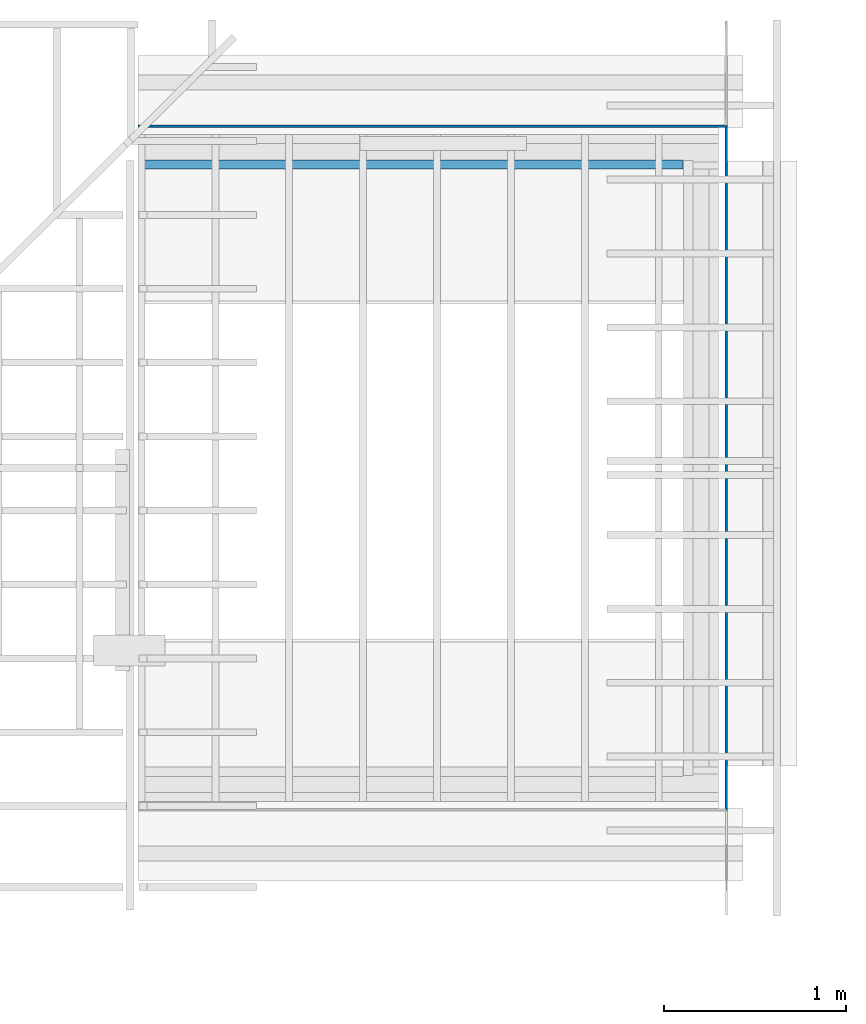
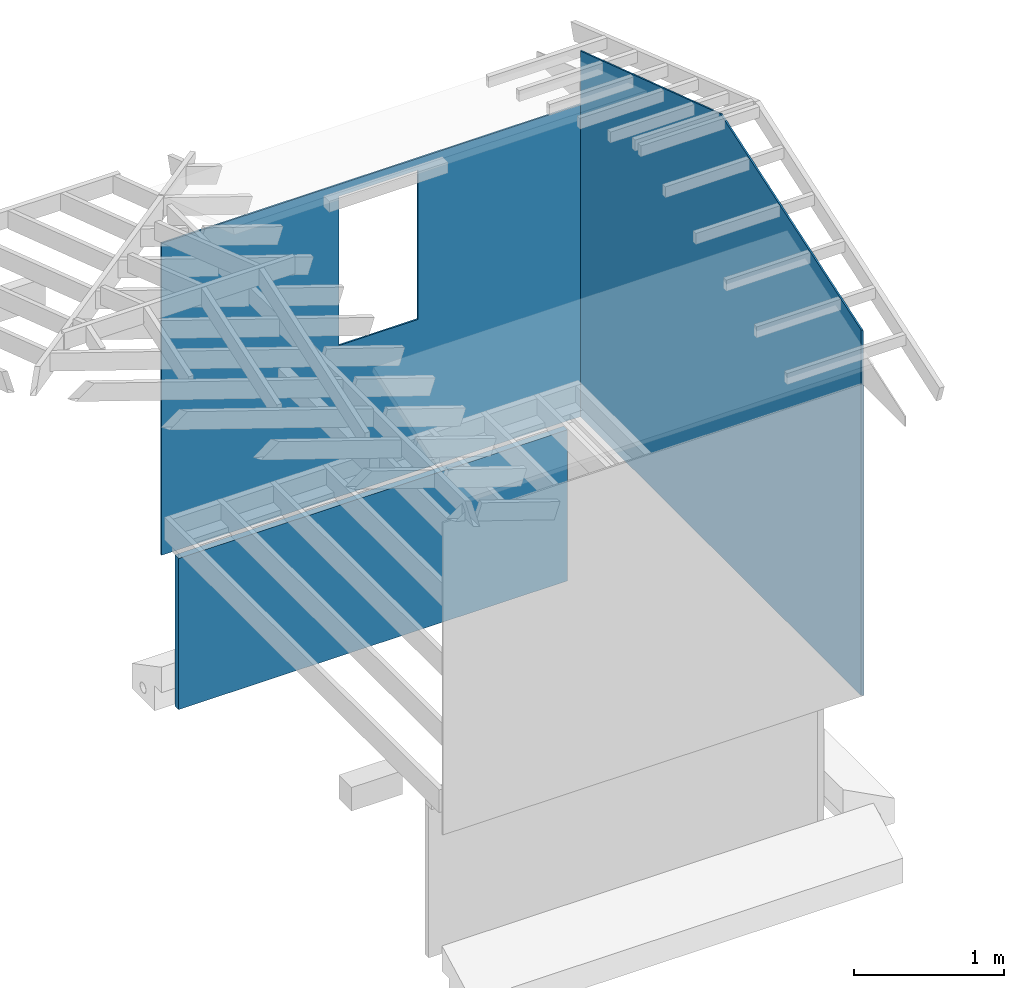
# Not in any storey, part 4 of 8: 3 walls, 2 openings.
"""IFC4 model written with IfcOpenShell, lengths in feet."""

from ifc_helpers import new_model, entity, si_unit, converted_unit, frame, origin_with_axes, origin_2d_with_axis, place, context, subcontext, project, line, indexed_curve, outline, extrude, clip, halfspace, material, layer, layer_set, layer_usage, type_object, element, save


model = new_model("IFC4")

# Units and contexts
model_context = context("Model", 3, precision=1e-05, world=origin_with_axes())
plan_context = context("Plan", 2, precision=1e-05, world=origin_2d_with_axis())
context_of_model_1 = context(None, 3, precision=1e-05, world=origin_with_axes())
context_of_model_2 = context(None, 3, precision=1e-05, world=origin_with_axes())
body_context = subcontext(model_context, "Body", "Model", "MODEL_VIEW")
ifc_project = project(units=[converted_unit("PLANEANGLEUNIT", "degree", entity("IfcReal", 0.0174532925199433), si_unit("PLANEANGLEUNIT", "RADIAN"), dimensions=[0, 0, 0, 0, 0, 0, 0]), converted_unit("AREAUNIT", "square foot", entity("IfcReal", 0.09290304), si_unit("AREAUNIT", "SQUARE_METRE"), dimensions=[2, 0, 0, 0, 0, 0, 0]), converted_unit("LENGTHUNIT", "foot", entity("IfcReal", 0.3048), si_unit("LENGTHUNIT", "METRE"), dimensions=[1, 0, 0, 0, 0, 0, 0]), converted_unit("VOLUMEUNIT", "cubic foot", entity("IfcReal", 0.0283168467116885), si_unit("VOLUMEUNIT", "CUBIC_METRE"), dimensions=[3, 0, 0, 0, 0, 0, 0])], contexts=[model_context, plan_context, context_of_model_1, context_of_model_2])

# Wall, opening
ifc_material_1 = material(Name="SIDING", Category="siding")
ifc_layer_1 = layer(ifc_material_1, 0.0416669994592667)
ifc_layer_set_1 = layer_set([ifc_layer_1])
ifc_layer_usage_1 = layer_usage(ifc_layer_set_1, "AXIS2", "POSITIVE", 0.0)
wall_type_1 = type_object("IfcWallType", PredefinedType="STANDARD", material=ifc_layer_set_1)
wall_1_placement = place(None, frame((-0.285811898276562, 9.16824957204303, -1.16348227490903), z_axis=(0.0, 0.0, 1.0), x_axis=(-0.999999999999924, -3.89414367418765e-07, 0.0)))
wall_1 = element("IfcWall", 1, at=wall_1_placement, type_object=wall_type_1, material=ifc_layer_usage_1, Name="Wall", context=body_context, shape_type="Clipping", body=[
    clip(extrude(outline(indexed_curve([(0.0, 0.0), (0.0, 0.0416669994592667), (10.6354163754604, 0.0416669994592667), (10.6354163754604, 0.0), (0.0, 0.0)], self_intersect=False)), origin_with_axes(), (0.0, 0.0, 1.0), 8.34589007645454), halfspace(frame((-5.02885222528038e-08, 6.70915058708965e-07, 1.16348227490903), z_axis=(-0.707105576992035, 0.707107841968536, 0.0), x_axis=(0.707107913674006, 0.707105648697275, 0.0)), False)),
])
opening_1_placement = place(wall_1_placement, frame((5.18517721883924, 0.0416680416636207, 6.07687500831023), z_axis=(4.76837129781377e-07, 0.999999999999885, -4.37113882867377e-08), x_axis=(0.99999999999981, -4.76837143992196e-07, -3.89414424262182e-07)))
element("IfcOpeningElement", 2, at=opening_1_placement, cuts=wall_1, Name="Opening", context=body_context, shape_type="SweptSolid", body=[
    extrude(outline(indexed_curve([(-0.966141327941824, 2.03659684639277), (-0.96614044795199, -1.95405223551072), (1.03534998621528, -1.95405223551072), (1.03534900844879, 2.03659684639277)], segments=[line(3, 2), line(2, 1), line(1, 4), line(4, 3)], self_intersect=False)), frame((0.0, 0.0, -0.820209973753281), z_axis=(0.0, 0.0, -1.0), x_axis=(-1.0, 0.0, 0.0)), (0.0, 0.0, -1.0), 1.64041994750656),
])

ifc_layer_usage_2 = layer_usage(ifc_layer_set_1, "AXIS2", "POSITIVE", 0.0)
wall_2_placement = place(None, frame((-0.28581282715472, -3.20128803178081, -1.16348227490903), z_axis=(0.0, 0.0, 1.0), x_axis=(3.13916473260163e-07, 0.999999999999951, 0.0)))
wall_2 = element("IfcWall", 3, at=wall_2_placement, type_object=wall_type_1, material=ifc_layer_usage_2, Name="Wall", context=body_context, shape_type="Clipping", body=[
    clip(clip(extrude(outline(indexed_curve([(0.0, 0.0), (0.0, 0.0416669994592667), (12.3695374596166, 0.0416669994592667), (12.3695374596166, 0.0), (0.0, 0.0)], self_intersect=False)), origin_with_axes(), (0.0, 0.0, 1.0), 12.9999998673366), halfspace(frame((-8.97213478781891e-08, -2.71705201353346e-08, 1.16348227490903), z_axis=(-0.707107663154602, 0.707105994224548, 0.0), x_axis=(0.707105946721084, 0.707107615651026, 0.0)), False)), halfspace(frame((12.3695376038238, -3.07907446987401e-08, 1.16348227490903), z_axis=(0.707107603549957, 0.707105994224548, 0.0), x_axis=(0.707105976523405, -0.707107585848774, 0.0)), False)),
])
opening_2_placement = place(wall_2_placement, frame((6.06700856311059, -2.63376047558779e-07, 13.4644495064192), z_axis=(0.0, -0.999999999999999, -4.37113882867378e-08), x_axis=(0.999999999999997, 0.0, -7.54979083694704e-08)))
element("IfcOpeningElement", 4, at=opening_2_placement, cuts=wall_2, Name="Opening", context=body_context, shape_type="SweptSolid", body=[
    extrude(outline(indexed_curve([(8.02534458831226, 1.85755235473002), (8.02534458831226, -4.34873063420373), (-8.26085959206729, -4.34872946088395), (-8.26085959206729, 1.8575535280498), (-0.117757294102134, -1.64557707904205)], segments=[line(5, 3), line(3, 4), line(4, 1), line(1, 2), line(2, 5)], self_intersect=False)), frame((0.0, 0.0, -0.820209973753281), z_axis=(0.0, 0.0, -1.0), x_axis=(-1.0, 0.0, 0.0)), (0.0, 0.0, -1.0), 1.64041994750656),
])

# Wall
ifc_material_2 = material(Category="InsulationBattVert")
ifc_layer_2 = layer(ifc_material_2, 0.166666999459267, Category="Materials")
ifc_layer_set_2 = layer_set([ifc_layer_2], Name="poche")
ifc_layer_usage_3 = layer_usage(ifc_layer_set_2, "AXIS2", "POSITIVE", 0.0)
wall_type_2 = type_object("IfcWallType", Name="EPS INSULATION", PredefinedType="STANDARD", material=ifc_layer_set_2)
wall_3_placement = place(None, frame((-1.08788880150462, 8.54324950320827, -4.83333204049138), z_axis=(0.0, 0.0, 1.0), x_axis=(-0.999999999999924, -3.89414367418765e-07, 0.0)))
element("IfcWall", 5, at=wall_3_placement, type_object=wall_type_2, material=ifc_layer_usage_3, Name="Wall", context=body_context, shape_type="SweptSolid", body=[
    extrude(outline(indexed_curve([(0.0, 0.0), (0.0, 0.166666999459267), (9.83333743385291, 0.166666999459267), (9.83333743385291, 0.0), (0.0, 0.0)], self_intersect=False)), origin_with_axes(), (0.0, 0.0, 1.0), 4.041670110282),
])

save(model, "model.ifc")
